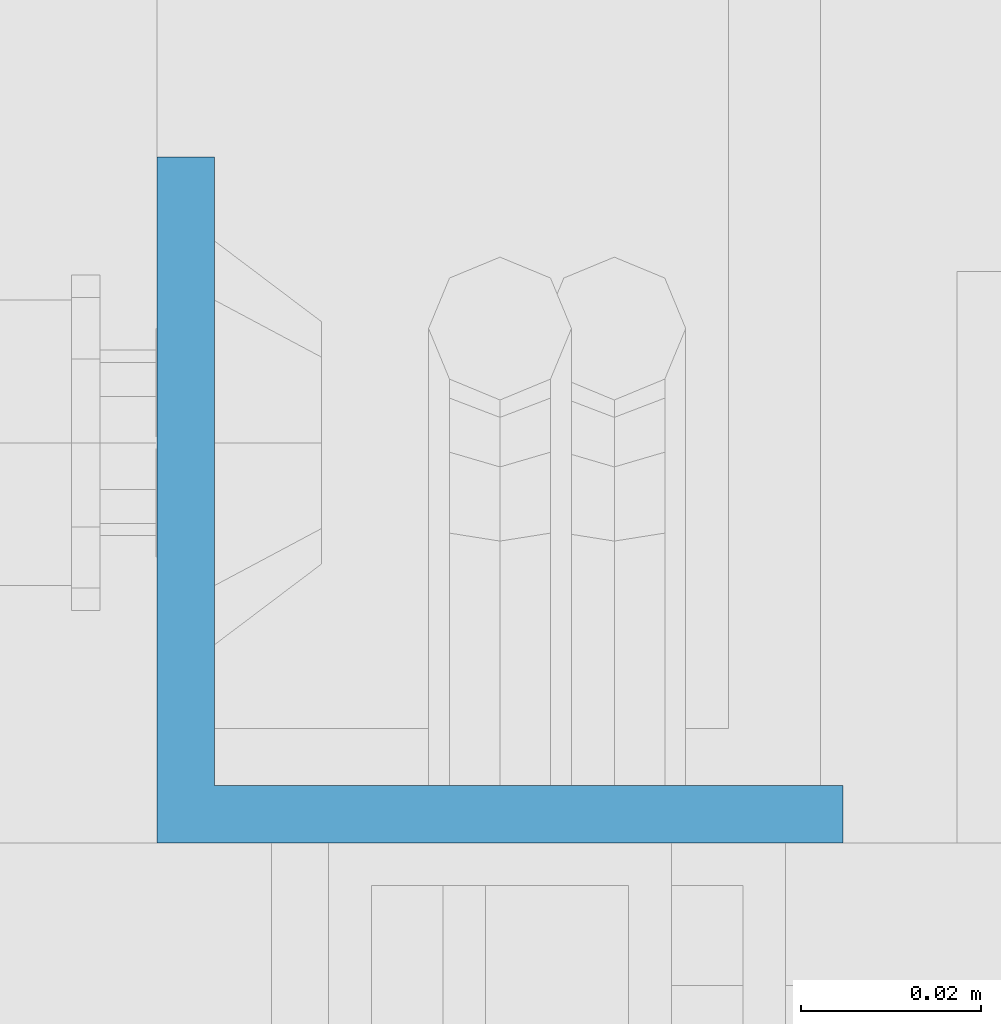
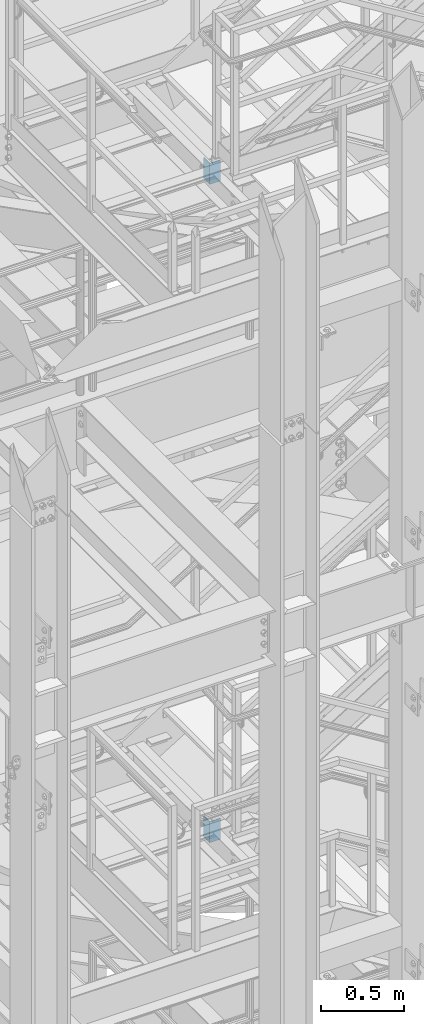
# One storey, part 820 of 1876: 2 columns, 2 elements without a shape of their own.
"""IFC2X3 building model written with IfcOpenShell, lengths in millimetres."""

from ifc_helpers import new_model, si_unit, frame, origin_with_axes, place, context, subcontext, project, spatial, faceted_brep, material, type_object, element, aggregate, save


model = new_model("IFC2X3")

# Units and contexts
model_context = context("Model", 3, precision=1e-05, world=origin_with_axes())
body_context = subcontext(model_context, "Body", "Model", "MODEL_VIEW")
ifc_project = project(units=[si_unit("LENGTHUNIT", "METRE", prefix="MILLI"), si_unit("AREAUNIT", "SQUARE_METRE"), si_unit("VOLUMEUNIT", "CUBIC_METRE"), si_unit("MASSUNIT", "GRAM", prefix="KILO"), si_unit("TIMEUNIT", "SECOND"), si_unit("PLANEANGLEUNIT", "RADIAN"), si_unit("SOLIDANGLEUNIT", "STERADIAN"), si_unit("THERMODYNAMICTEMPERATUREUNIT", "DEGREE_CELSIUS"), si_unit("LUMINOUSINTENSITYUNIT", "LUMEN")], contexts=[model_context])

# Site, building, storey
site_placement = place(None, origin_with_axes())
site = spatial("IfcSite", under=ifc_project, at=site_placement, CompositionType="ELEMENT")
building_placement = place(site_placement, origin_with_axes())
building = spatial("IfcBuilding", under=site, at=building_placement, Name="Undefined", CompositionType="ELEMENT")
storey_placement = place(building_placement, origin_with_axes())
storey = spatial("IfcBuildingStorey", under=building, at=storey_placement, Name="Undefined", CompositionType="ELEMENT", Elevation=0.0)

# Assembly, column
assembly_1_placement = place(storey_placement, origin_with_axes())
assembly_1 = element("IfcElementAssembly", 1, at=assembly_1_placement, inside=storey, Name="STRINGER", AssemblyPlace="NOTDEFINED", PredefinedType="RIGID_FRAME")
ifc_material = material(Name="STEEL/A36")
column_type = type_object("IfcColumnType", Name="L3X3X1/4", PredefinedType="NOTDEFINED")
column_1_placement = place(assembly_1_placement, frame((2019.30000034182, -5676.90000114549, 10556.875), z_axis=(1.0, 0.0, 0.0), x_axis=(0.0, 0.0, 1.0)))
column_1 = element("IfcColumn", 2, at=column_1_placement, type_object=column_type, material=ifc_material, Name="ANGLE", ObjectType="L3X3X1/4", context=body_context, shape_type="Brep", body=[
    faceted_brep([(0.0, 38.1000000000004, -38.1), (0.0, 38.1000000000004, 38.1), (152.4, 38.1000000000004, 38.1), (152.4, 38.1000000000004, -38.1), (0.0, 31.75, 38.1000000000004), (152.4, 31.75, 38.0999999999999), (0.0, 31.75, -31.75), (152.4, 31.75, -31.75), (0.0, -38.1000000000004, -31.75), (152.4, -38.1000000000004, -31.75), (0.0, -38.1000000000004, -38.1), (152.4, -38.1000000000004, -38.1)], [[[0, 1, 2, 3]], [[1, 4, 5, 2]], [[4, 6, 7, 5]], [[6, 8, 9, 7]], [[8, 10, 11, 9]], [[10, 0, 3, 11]], [[5, 7, 9, 11, 3, 2]], [[10, 8, 6, 4, 1, 0]]]),
])
aggregate(assembly_1, [column_1])

assembly_2_placement = place(storey_placement, origin_with_axes())
assembly_2 = element("IfcElementAssembly", 3, at=assembly_2_placement, inside=storey, Name="STRINGER", AssemblyPlace="NOTDEFINED", PredefinedType="RIGID_FRAME")
column_2_placement = place(assembly_2_placement, frame((2019.29999999991, -5676.90000114549, 15385.2268514434), z_axis=(1.0, 0.0, 0.0), x_axis=(0.0, 0.0, 1.0)))
column_2 = element("IfcColumn", 4, at=column_2_placement, type_object=column_type, material=ifc_material, Name="ANGLE", ObjectType="L3X3X1/4", context=body_context, shape_type="Brep", body=[
    faceted_brep([(0.0, 38.1000000000004, -38.1), (0.0, 38.1000000000004, 38.1), (152.4, 38.1000000000004, 38.1), (152.4, 38.1000000000004, -38.1), (0.0, 31.75, 38.1000000000004), (152.4, 31.75, 38.0999999999999), (0.0, 31.75, -31.75), (152.4, 31.75, -31.75), (0.0, -38.1000000000004, -31.75), (152.4, -38.1000000000004, -31.75), (0.0, -38.1000000000004, -38.1), (152.4, -38.1000000000004, -38.1)], [[[0, 1, 2, 3]], [[1, 4, 5, 2]], [[4, 6, 7, 5]], [[6, 8, 9, 7]], [[8, 10, 11, 9]], [[10, 0, 3, 11]], [[5, 7, 9, 11, 3, 2]], [[10, 8, 6, 4, 1, 0]]]),
])
aggregate(assembly_2, [column_2])

save(model, "model.ifc")
